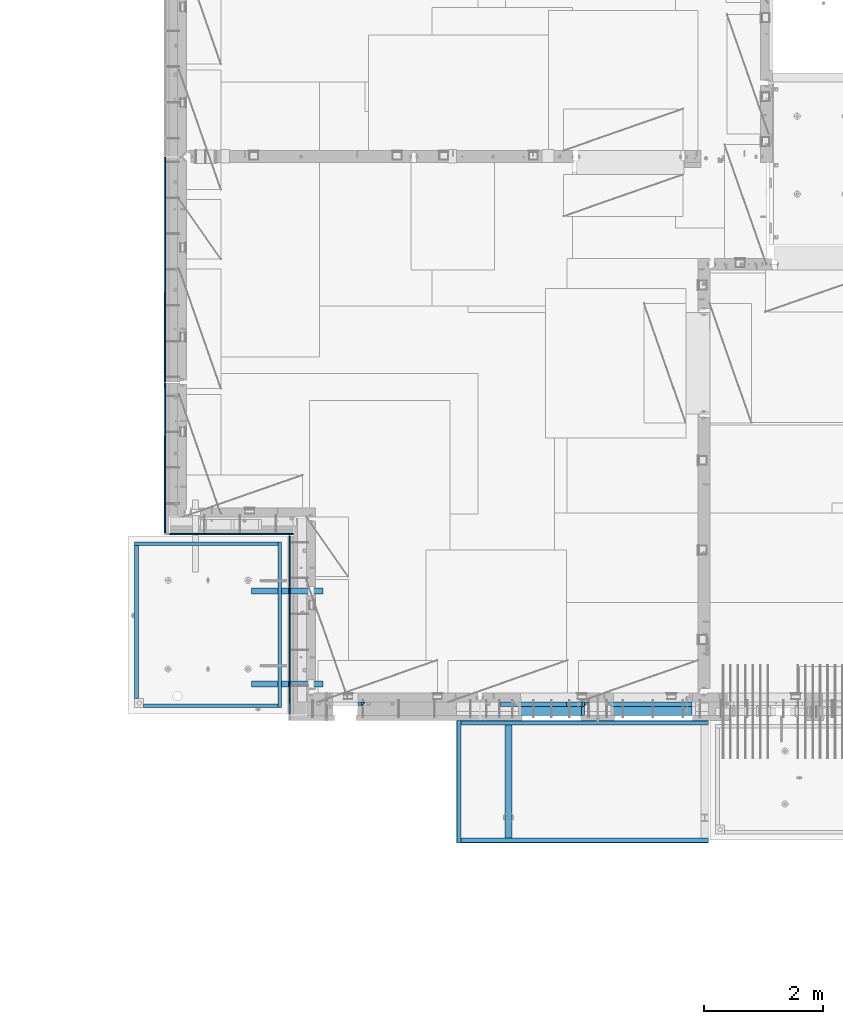
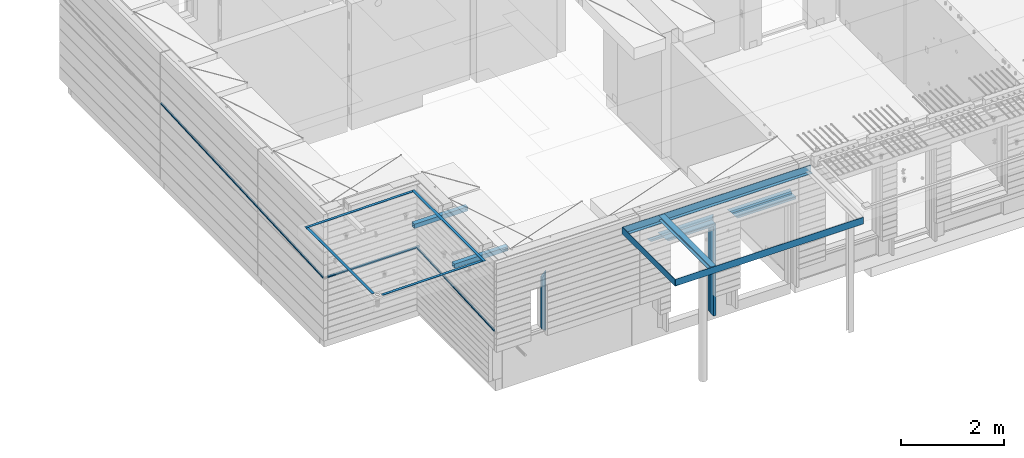
# One storey, part 85 of 325: 25 beams, 13 elements without a shape of their own.
"""IFC2X3 building model written with IfcOpenShell, lengths in millimetres."""

from ifc_helpers import new_model, si_unit, frame, origin_with_axes, place, context, subcontext, project, spatial, faceted_brep, material, type_object, element, aggregate, save


model = new_model("IFC2X3")

# Units and contexts
model_context = context("Model", 3, precision=1e-05, world=origin_with_axes())
body_context = subcontext(model_context, "Body", "Model", "MODEL_VIEW")
ifc_project = project(units=[si_unit("LENGTHUNIT", "METRE", prefix="MILLI"), si_unit("AREAUNIT", "SQUARE_METRE"), si_unit("VOLUMEUNIT", "CUBIC_METRE"), si_unit("MASSUNIT", "GRAM", prefix="KILO"), si_unit("TIMEUNIT", "SECOND"), si_unit("PLANEANGLEUNIT", "RADIAN"), si_unit("SOLIDANGLEUNIT", "STERADIAN"), si_unit("THERMODYNAMICTEMPERATUREUNIT", "DEGREE_CELSIUS"), si_unit("LUMINOUSINTENSITYUNIT", "LUMEN")], contexts=[model_context])

# Site, building, storey
site_placement = place(None, origin_with_axes())
site = spatial("IfcSite", under=ifc_project, at=site_placement, CompositionType="ELEMENT")
building_placement = place(site_placement, origin_with_axes())
building = spatial("IfcBuilding", under=site, at=building_placement, CompositionType="ELEMENT")
storey_placement = place(building_placement, origin_with_axes())
storey = spatial("IfcBuildingStorey", under=building, at=storey_placement, Name="1", CompositionType="ELEMENT", Elevation=0.0)

# Assembly, beams
assembly_1_placement = place(storey_placement, origin_with_axes())
assembly_1 = element("IfcElementAssembly", 1, at=assembly_1_placement, inside=storey, AssemblyPlace="NOTDEFINED", PredefinedType="REINFORCEMENT_UNIT")
ifc_material_1 = material(Name="CONCRETE/C25/30")
beam_type_1 = type_object("IfcBeamType", PredefinedType="NOTDEFINED")
beam_1_placement = place(assembly_1_placement, frame((15034.9997605339, 7815.0, 83940.0), z_axis=(0.0, 0.0, -1.0), x_axis=(1.0, 0.0, 0.0)))
beam_1 = element("IfcBeam", 2, at=beam_1_placement, type_object=beam_type_1, material=ifc_material_1, context=body_context, shape_type="Brep", body=[
    faceted_brep([(1425.00019073487, -35.0, 35.0), (1425.00019073487, -35.0, -35.0), (1425.00019073487, 35.0, 35.0), (70.0000000000164, -35.0, 35.0), (70.0000000000164, 35.0, 35.0), (0.0, -35.0, -35.0)], [[[0, 1, 2]], [[3, 0, 2, 4]], [[3, 4, 5]], [[0, 3, 5, 1]], [[4, 2, 1, 5]]]),
])
beam_2_placement = place(assembly_1_placement, frame((13485.0003327385, 7815.0, 83940.0), z_axis=(0.0, 0.0, -1.0), x_axis=(1.0, 0.0, 0.0)))
beam_2 = element("IfcBeam", 3, at=beam_2_placement, type_object=beam_type_1, material=ifc_material_1, context=body_context, shape_type="Brep", body=[
    faceted_brep([(70.0000000000164, -35.0, 35.0), (70.0000000000164, 35.0, 35.0), (0.0, -35.0, -35.0), (1249.99904632568, -35.0, -35.0), (1179.99904632569, -35.0, 35.0), (1179.99904632569, 35.0, 35.0)], [[[0, 1, 2]], [[0, 2, 3, 4]], [[1, 0, 4, 5]], [[2, 1, 5, 3]], [[4, 3, 5]]]),
])
beam_3_placement = place(assembly_1_placement, frame((14699.9993790642, 7815.0, 83975.0), z_axis=(-1.0, 3.00000001838171e-08, 0.0), x_axis=(0.0, 0.0, -1.0)))
beam_3 = element("IfcBeam", 4, at=beam_3_placement, type_object=beam_type_1, material=ifc_material_1, context=body_context, shape_type="Brep", body=[
    faceted_brep([(2245.0, -35.0, 35.0), (70.0000000000164, -35.0, 35.0), (0.0, -35.0, -35.0), (2245.0, -35.0, -35.0), (2245.0, 35.0, 35.0), (70.0000000000164, 35.0, 35.0)], [[[0, 1, 2, 3]], [[0, 3, 4]], [[1, 0, 4, 5]], [[1, 5, 2]], [[4, 3, 2, 5]]]),
])
beam_type_2 = type_object("IfcBeamType", PredefinedType="NOTDEFINED")
beam_4_placement = place(assembly_1_placement, frame((13255.0003327385, 7815.0, 83880.0), z_axis=(0.0, 0.0, -1.0), x_axis=(1.0, 0.0, 0.0)))
beam_4 = element("IfcBeam", 5, at=beam_4_placement, type_object=beam_type_2, material=ifc_material_1, context=body_context, shape_type="Brep", body=[
    faceted_brep([(345.640071966709, 35.0, 25.0), (343.845200171838, -35.0, 25.0), (343.845200171838, -35.0, 18.8461538461561), (345.640071966709, 35.0, 20.6410256410309), (50.0000000000036, 35.0, 25.0), (50.0000000000055, -35.0, 25.0), (0.0, 35.0, -25.0), (0.0, -35.0, -25.0), (1109.99904632568, -35.0, -25.0), (1066.15289247952, -35.0, 18.8461538461561), (1064.35802068466, 35.0, 20.6410256410309), (1109.99904632568, 35.0, -25.0)], [[[0, 1, 2, 3]], [[1, 0, 4, 5]], [[6, 7, 5, 4]], [[2, 1, 5, 7, 8, 9]], [[3, 2, 9, 10]], [[6, 4, 0, 3, 10, 11]], [[7, 6, 11, 8]], [[10, 9, 8, 11]]]),
])
beam_5_placement = place(assembly_1_placement, frame((15104.9997605339, 7815.0, 83880.0), z_axis=(0.0, 0.0, -1.0), x_axis=(1.0, 0.0, 0.0)))
beam_5 = element("IfcBeam", 6, at=beam_5_placement, type_object=beam_type_2, material=ifc_material_1, context=body_context, shape_type="Brep", body=[
    faceted_brep([(1355.00019073487, -35.0, -25.0), (1355.00019073487, 35.0, -25.0), (1355.00019073487, 35.0, 20.6410256410309), (1355.00019073487, -35.0, 18.8461538461561), (45.6412163758905, 35.0, 20.6410256410309), (43.8463445810194, -35.0, 18.8461538461561), (0.0, -35.0, -25.0), (0.0, 35.0, -25.0)], [[[0, 1, 2, 3]], [[3, 2, 4, 5]], [[0, 3, 5, 6]], [[1, 0, 6, 7]], [[2, 1, 7, 4]], [[6, 5, 4, 7]]]),
])
beam_6_placement = place(assembly_1_placement, frame((14639.9993790642, 7815.0, 83905.0), z_axis=(-1.0, 3.00000001838171e-08, 0.0), x_axis=(0.0, 0.0, -1.0)))
beam_6 = element("IfcBeam", 7, at=beam_6_placement, type_object=beam_type_2, material=ifc_material_1, context=body_context, shape_type="Brep", body=[
    faceted_brep([(2175.0, -35.0, -25.0), (2175.0, 35.0, -25.0), (2175.0, 35.0, 20.6410256410254), (2175.0, -35.0, 18.8461538461543), (63.8461538461561, -35.0, 18.8461538461543), (2155.0, -35.0, 18.8461538461543), (2155.0, 35.0, 20.6410256410254), (65.6410256410309, 35.0, 20.6410256410254), (45.6410256410309, 35.0, 20.6410256410254), (43.8461538461561, -35.0, 18.8461538461543), (0.0, 35.0, -25.0), (0.0, -35.0, -25.0)], [[[0, 1, 2, 3]], [[4, 5, 6, 7, 8, 9]], [[1, 10, 8, 7, 6, 2]], [[5, 3, 2, 6]], [[4, 9, 11, 0, 3, 5]], [[8, 10, 11, 9]], [[11, 10, 1, 0]]]),
])
ifc_material_2 = material(Name="TIMBER")
beam_type_3 = type_object("IfcBeamType", Name="50X150", PredefinedType="NOTDEFINED")
beam_7_placement = place(assembly_1_placement, frame((15104.9997605339, 7705.0, 83880.0), z_axis=(0.0, 0.0, -1.0), x_axis=(1.0, 0.0, 0.0)))
beam_7 = element("IfcBeam", 8, at=beam_7_placement, type_object=beam_type_3, material=ifc_material_2, ObjectType="50X150", context=body_context, shape_type="Brep", body=[
    faceted_brep([(1354.66019073487, -75.0, 25.0), (1354.66019073487, -75.0, -25.0), (1354.66019073487, 75.0, -25.0), (1354.66019073487, 75.0, 25.0), (50.0000000000036, -75.0, 25.0), (0.0, -75.0, -25.0), (0.0, 75.0, -25.0), (50.0000000000036, 75.0, 25.0)], [[[0, 1, 2, 3]], [[1, 0, 4, 5]], [[2, 1, 5, 6]], [[3, 2, 6, 7]], [[0, 3, 7, 4]], [[4, 7, 6, 5]]]),
])
beam_8_placement = place(assembly_1_placement, frame((13555.0003327385, 7705.0, 83880.0), z_axis=(0.0, 0.0, -1.0), x_axis=(1.0, 0.0, 0.0)))
beam_8 = element("IfcBeam", 9, at=beam_8_placement, type_object=beam_type_3, material=ifc_material_2, ObjectType="50X150", context=body_context, shape_type="Brep", body=[
    faceted_brep([(50.0000000000036, -75.0, 25.0), (50.0000000000036, 75.0, 25.0), (0.0, 75.0, -25.0), (0.0, -75.0, -25.0), (1109.99904632568, -75.0, -25.0), (1059.99904632568, -75.0, 25.0), (1059.99904632568, 75.0, 25.0), (1109.99904632568, 75.0, -25.0)], [[[0, 1, 2, 3]], [[0, 3, 4, 5]], [[1, 0, 5, 6]], [[2, 1, 6, 7]], [[3, 2, 7, 4]], [[6, 5, 4, 7]]]),
])
beam_9_placement = place(assembly_1_placement, frame((14639.9993790642, 7705.0, 83905.0), z_axis=(-1.0, 3.00000001838171e-08, 0.0), x_axis=(0.0, 0.0, -1.0)))
beam_9 = element("IfcBeam", 10, at=beam_9_placement, type_object=beam_type_3, material=ifc_material_2, ObjectType="50X150", context=body_context, shape_type="Brep", body=[
    faceted_brep([(2175.0, -75.0, 25.0), (2175.0, -75.0, -25.0), (2175.0, 75.0, -25.0), (2175.0, 75.0, 25.0), (0.0, -75.0, -25.0), (0.0, 75.0, -25.0), (50.0000000000036, 75.0, 25.0), (50.0000000000036, -75.0, 25.0)], [[[0, 1, 2, 3]], [[4, 5, 2, 1]], [[3, 2, 5, 6]], [[0, 3, 6, 7]], [[1, 0, 7, 4]], [[7, 6, 5, 4]]]),
])
aggregate(assembly_1, [beam_1, beam_4, beam_5, beam_2, beam_7, beam_6, beam_3, beam_8, beam_9])

# Assembly, beam
assembly_2_placement = place(storey_placement, origin_with_axes())
assembly_2 = element("IfcElementAssembly", 11, at=assembly_2_placement, inside=storey, AssemblyPlace="NOTDEFINED", PredefinedType="REINFORCEMENT_UNIT")
ifc_material_3 = material(Name="TIMBER/T24")
beam_type_4 = type_object("IfcBeamType", PredefinedType="NOTDEFINED")
beam_10_placement = place(assembly_2_placement, frame((9722.5, 10631.2198813113, 83239.1084473989), z_axis=(1.0, 0.0, 0.0), x_axis=(0.0, -0.998808802312005, -0.0487952500153176)))
beam_10 = element("IfcBeam", 12, at=beam_10_placement, type_object=beam_type_4, material=ifc_material_3, context=body_context, shape_type="Brep", body=[
    faceted_brep([(9.72067937254906e-09, -25.0049072368565, -2.50000010478834), (-1.81898940354586e-12, -0.00592035360750742, -12.5), (2988.55996575396, -1.2821692507714e-07, -12.5), (2988.55996575396, -25.0, -2.49999958879198), (0.0, 25.0, -12.5), (0.0, 25.0, 12.5), (2988.55996575396, 25.0, 12.5), (2988.55996575396, 25.0, -12.5), (0.0, -25.0, 12.5), (2988.55996575396, -25.0, 12.5)], [[[0, 1, 2, 3]], [[4, 5, 6, 7]], [[5, 8, 9, 6]], [[9, 8, 0, 3]], [[7, 6, 9, 3, 2]], [[4, 7, 2, 1]], [[8, 5, 4, 1, 0]]]),
])
aggregate(assembly_2, [beam_10])

assembly_3_placement = place(storey_placement, origin_with_axes())
assembly_3 = element("IfcElementAssembly", 13, at=assembly_3_placement, inside=storey, AssemblyPlace="NOTDEFINED", PredefinedType="REINFORCEMENT_UNIT")
beam_11_placement = place(assembly_3_placement, frame((7725.00005960496, 10662.5, 83239.8157983143), z_axis=(0.0, 1.0, 0.0), x_axis=(1.0, 0.0, 0.0)))
beam_11 = element("IfcBeam", 14, at=beam_11_placement, type_object=beam_type_4, material=ifc_material_3, context=body_context, shape_type="Brep", body=[
    faceted_brep([(2060.00479019237, -24.9999999999854, 0.0), (0.0, -25.0, 0.0), (-1.45519152283669e-11, -3.63797880709171e-12, -12.5), (2060.00479019237, 1.45519152283669e-11, -12.5), (0.0, 25.0, -12.5), (0.0, 25.0, 12.5), (2060.00479019237, 25.0, 12.5), (2060.00479019237, 25.0, -12.5), (0.0, -25.0, 12.5), (2060.00479019237, -25.0, 12.5)], [[[0, 1, 2, 3]], [[4, 5, 6, 7]], [[5, 8, 9, 6]], [[7, 6, 9, 0, 3]], [[4, 7, 3, 2]], [[8, 5, 4, 2, 1]], [[9, 8, 1, 0]]]),
])
aggregate(assembly_3, [beam_11])

assembly_4_placement = place(storey_placement, origin_with_axes())
assembly_4 = element("IfcElementAssembly", 15, at=assembly_4_placement, inside=storey, AssemblyPlace="NOTDEFINED", PredefinedType="REINFORCEMENT_UNIT")
beam_12_placement = place(assembly_4_placement, frame((7642.5, 13196.2344335996, 83364.4291608322), z_axis=(1.0, 0.0, 0.0), x_axis=(0.0, -0.998780195036966, -0.0493773430018267)))
beam_12 = element("IfcBeam", 16, at=beam_12_placement, type_object=beam_type_4, material=ifc_material_3, context=body_context, shape_type="Brep", body=[
    faceted_brep([(-0.000167481186508667, -25.1808586047118, -0.208622932433173), (-3.63797880709171e-12, -0.00150569378456566, -12.5), (2523.07761831955, -2.33796088455711, -12.5), (2523.07761831955, -25.0000000000146, -1.43745732237585), (0.0, 25.0, -12.5), (0.0, 25.0, 12.5), (2523.07761831955, 25.0, 12.5), (2523.07761831955, 25.0, -12.5), (0.0, -25.0, 12.5), (2523.07761831955, -25.0000000000146, 12.5)], [[[0, 1, 2, 3]], [[4, 5, 6, 7]], [[5, 8, 9, 6]], [[9, 8, 0, 3]], [[7, 6, 9, 3, 2]], [[4, 7, 2, 1]], [[8, 5, 4, 1, 0]]]),
])
aggregate(assembly_4, [beam_12])

assembly_5_placement = place(storey_placement, origin_with_axes())
assembly_5 = element("IfcElementAssembly", 17, at=assembly_5_placement, inside=storey, AssemblyPlace="NOTDEFINED", PredefinedType="REINFORCEMENT_UNIT")
beam_13_placement = place(assembly_5_placement, frame((7642.5, 16971.1699461518, 83548.8576061738), z_axis=(1.0, 0.0, 0.0), x_axis=(0.0, -0.998808676266891, -0.0487978300130376)))
beam_13 = element("IfcBeam", 18, at=beam_13_placement, type_object=beam_type_4, material=ifc_material_3, context=body_context, shape_type="Brep", body=[
    faceted_brep([(-6.3338487962028e-05, -25.1831539043487, -0.208622932433173), (-3.63797880709171e-12, -0.00381015073799063, -12.5), (3764.43457031995, -1.3056310826214, -12.5), (3764.43457031995, -25.0, -0.933518151315184), (0.0, 25.0, -12.5), (0.0, 25.0, 12.5), (3764.43457031994, 25.0, 12.5), (3764.43457031994, 25.0, -12.5), (0.0, -25.0, 12.5), (3764.43457031995, -25.0, 12.5)], [[[0, 1, 2, 3]], [[4, 5, 6, 7]], [[5, 8, 9, 6]], [[9, 8, 0, 3]], [[7, 6, 9, 3, 2]], [[4, 7, 2, 1]], [[8, 5, 4, 1, 0]]]),
])
aggregate(assembly_5, [beam_13])

# Assemblies, beams
assembly_6_placement = place(storey_placement, origin_with_axes())
assembly_6 = element("IfcElementAssembly", 19, at=assembly_6_placement, inside=storey, AssemblyPlace="NOTDEFINED", PredefinedType="REINFORCEMENT_UNIT")
assembly_7_placement = place(assembly_6_placement, origin_with_axes())
assembly_7 = element("IfcElementAssembly", 20, at=assembly_7_placement, AssemblyPlace="NOTDEFINED", PredefinedType="NOTDEFINED")
ifc_material_4 = material(Name="Undefined/350")
beam_type_5 = type_object("IfcBeamType", Name="100X100X5", PredefinedType="NOTDEFINED")
beam_14_placement = place(assembly_7_placement, frame((9089.99655739692, 9710.00014320107, 84555.0), z_axis=(0.0, 0.0, 1.0), x_axis=(0.999999999752625, -2.22429999942101e-05, 0.0)))
beam_14 = element("IfcBeam", 21, at=beam_14_placement, type_object=beam_type_5, material=ifc_material_4, ObjectType="100X100X5", context=body_context, shape_type="Brep", body=[
    faceted_brep([(1156.2510802317, 44.9999999999982, 10.8253175473074), (1156.25107855315, 50.0256005946221, 10.8253175473074), (1160.82639610046, 50.0256021227788, 6.25), (1160.82639777901, 44.9999999999982, 6.25), (1150.00108023171, 44.9999999999982, 12.5), (1150.00107855316, 50.0255985071226, 12.5), (1143.75108023171, 44.9999999999982, 10.8253175473074), (1143.75107855316, 50.0255964196231, 10.8253175473074), (1139.1757626844, 44.9999999999982, 6.25), (1139.17576100585, 50.0255948914664, 6.25), (1137.5010802317, 44.9999999999982, 0.0), (1137.50107855316, 50.0255943321226, 0.0), (1139.1757626844, 44.9999999999982, -6.25), (1139.17576100585, 50.0255948914664, -6.25), (1143.75108023171, 44.9999999999982, -10.8253175473074), (1143.75107855316, 50.0255964196231, -10.8253175473074), (1150.00108023171, 44.9999999999982, -12.5), (1150.00107855316, 50.0255985071226, -12.5), (1156.2510802317, 44.9999999999982, -10.8253175473074), (1156.25107855315, 50.0256005946221, -10.8253175473074), (1160.82639777901, 44.9999999999982, -6.25), (1160.82639610046, 50.0256021227788, -6.25), (1162.50108023171, 44.9999999999982, 0.0), (1162.50107855316, 50.0256026821226, 0.0), (1156.25111195316, -49.9743994042774, 10.8253175473074), (1156.25111029171, -44.9999999999991, 10.8253175473074), (1160.82642783901, -44.9999999999991, 6.25), (1160.82642950046, -49.9743978761207, 6.25), (1150.00111195316, -49.9744014917787, 12.5), (1150.00111029171, -44.9999999999991, 12.5), (1143.75111195316, -49.9744035792783, 10.8253175473074), (1143.75111029171, -44.9999999999991, 10.8253175473074), (1139.17579440585, -49.9744051074349, 6.25), (1139.1757927444, -44.9999999999991, 6.25), (1137.50111195316, -49.9744056667778, 0.0), (1137.50111029171, -44.9999999999991, 0.0), (1139.17579440585, -49.9744051074349, -6.25), (1139.1757927444, -44.9999999999991, -6.25), (1143.75111195316, -49.9744035792783, -10.8253175473074), (1143.75111029171, -44.9999999999991, -10.8253175473074), (1150.00111195316, -49.9744014917787, -12.5), (1150.00111029171, -44.9999999999991, -12.5), (1156.25111195316, -49.9743994042774, -10.8253175473074), (1156.25111029171, -44.9999999999991, -10.8253175473074), (1160.82642950046, -49.9743978761207, -6.25), (1160.82642783901, -44.9999999999991, -6.25), (1162.50111195316, -49.9743973167779, 0.0), (1162.50111029171, -44.9999999999991, 0.0), (1.81898940354586e-12, -50.0000000000009, -50.0), (1.81898940354586e-12, 49.9999999999991, -50.0), (1200.00449189278, 49.9999999999982, -50.0), (1200.00449189278, -50.0000000000009, -50.0), (1.81898940354586e-12, 49.9999999999991, 50.0), (1.81898940354586e-12, -50.0000000000009, 50.0), (1200.00449189278, -50.0000000000009, 50.0), (1200.00449189278, 49.9999999999982, 50.0), (0.0, 44.9999999999991, 45.0), (1.81898940354586e-12, -45.0000000000009, 45.0), (1.81898940354586e-12, -45.0000000000009, -45.0), (0.0, 44.9999999999991, -45.0), (1200.00449189278, 44.9999999999982, -45.0), (1200.00449189278, 44.9999999999982, 45.0), (1200.00449189278, -45.0000000000009, 45.0), (1200.00449189278, -45.0000000000009, -45.0)], [[[0, 1, 2, 3]], [[4, 5, 1, 0]], [[6, 7, 5, 4]], [[8, 9, 7, 6]], [[10, 11, 9, 8]], [[12, 13, 11, 10]], [[14, 15, 13, 12]], [[16, 17, 15, 14]], [[18, 19, 17, 16]], [[20, 21, 19, 18]], [[22, 23, 21, 20]], [[3, 2, 23, 22]], [[24, 25, 26, 27]], [[28, 29, 25, 24]], [[30, 31, 29, 28]], [[32, 33, 31, 30]], [[34, 35, 33, 32]], [[36, 37, 35, 34]], [[38, 39, 37, 36]], [[40, 41, 39, 38]], [[42, 43, 41, 40]], [[44, 45, 43, 42]], [[46, 47, 45, 44]], [[27, 26, 47, 46]], [[48, 49, 50, 51]], [[52, 53, 54, 55]], [[49, 52, 55, 50], [1, 5, 7, 9, 11, 13, 15, 17, 19, 21, 23, 2]], [[48, 53, 52, 49], [56, 57, 58, 59]], [[56, 59, 60, 61], [18, 16, 14, 12, 10, 8, 6, 4, 0, 3, 22, 20]], [[57, 56, 61, 62]], [[58, 57, 62, 63], [25, 29, 31, 33, 35, 37, 39, 41, 43, 45, 47, 26]], [[59, 58, 63, 60]], [[54, 51, 50, 55], [62, 61, 60, 63]], [[53, 48, 51, 54], [42, 40, 38, 36, 34, 32, 30, 28, 24, 27, 46, 44]]]),
])
aggregate(assembly_7, [beam_14])
assembly_8_placement = place(assembly_6_placement, origin_with_axes())
assembly_8 = element("IfcElementAssembly", 22, at=assembly_8_placement, AssemblyPlace="NOTDEFINED", PredefinedType="NOTDEFINED")
beam_15_placement = place(assembly_8_placement, frame((9089.99655739692, 8155.00014320107, 84555.0), z_axis=(0.0, 0.0, 1.0), x_axis=(0.999999999752625, -2.22429999942101e-05, 0.0)))
beam_15 = element("IfcBeam", 23, at=beam_15_placement, type_object=beam_type_5, material=ifc_material_4, ObjectType="100X100X5", context=body_context, shape_type="Brep", body=[
    faceted_brep([(1156.2510802317, 44.9999999999982, 10.8253175473074), (1156.25107855315, 50.0256005946221, 10.8253175473074), (1160.82639610046, 50.0256021227788, 6.25), (1160.82639777901, 44.9999999999982, 6.25), (1150.00108023171, 44.9999999999982, 12.5), (1150.00107855316, 50.0255985071226, 12.5), (1143.75108023171, 44.9999999999982, 10.8253175473074), (1143.75107855316, 50.0255964196231, 10.8253175473074), (1139.1757626844, 44.9999999999982, 6.25), (1139.17576100585, 50.0255948914664, 6.25), (1137.5010802317, 44.9999999999982, 0.0), (1137.50107855316, 50.0255943321226, 0.0), (1139.1757626844, 44.9999999999982, -6.25), (1139.17576100585, 50.0255948914664, -6.25), (1143.75108023171, 44.9999999999982, -10.8253175473074), (1143.75107855316, 50.0255964196231, -10.8253175473074), (1150.00108023171, 44.9999999999982, -12.5), (1150.00107855316, 50.0255985071226, -12.5), (1156.2510802317, 44.9999999999982, -10.8253175473074), (1156.25107855315, 50.0256005946221, -10.8253175473074), (1160.82639777901, 44.9999999999982, -6.25), (1160.82639610046, 50.0256021227788, -6.25), (1162.50108023171, 44.9999999999982, 0.0), (1162.50107855316, 50.0256026821226, 0.0), (1156.25111195316, -49.9743994042774, 10.8253175473074), (1156.25111029171, -44.9999999999991, 10.8253175473074), (1160.82642783901, -44.9999999999991, 6.25), (1160.82642950046, -49.9743978761207, 6.25), (1150.00111195316, -49.9744014917787, 12.5), (1150.00111029171, -44.9999999999991, 12.5), (1143.75111195316, -49.9744035792783, 10.8253175473074), (1143.75111029171, -44.9999999999991, 10.8253175473074), (1139.17579440585, -49.9744051074349, 6.25), (1139.1757927444, -44.9999999999991, 6.25), (1137.50111195316, -49.9744056667778, 0.0), (1137.50111029171, -44.9999999999991, 0.0), (1139.17579440585, -49.9744051074349, -6.25), (1139.1757927444, -44.9999999999991, -6.25), (1143.75111195316, -49.9744035792783, -10.8253175473074), (1143.75111029171, -44.9999999999991, -10.8253175473074), (1150.00111195316, -49.9744014917787, -12.5), (1150.00111029171, -44.9999999999991, -12.5), (1156.25111195316, -49.9743994042774, -10.8253175473074), (1156.25111029171, -44.9999999999991, -10.8253175473074), (1160.82642950046, -49.9743978761207, -6.25), (1160.82642783901, -44.9999999999991, -6.25), (1162.50111195316, -49.9743973167779, 0.0), (1162.50111029171, -44.9999999999991, 0.0), (1.81898940354586e-12, -50.0000000000009, -50.0), (1.81898940354586e-12, 49.9999999999991, -50.0), (1200.00449189278, 49.9999999999982, -50.0), (1200.00449189278, -50.0000000000009, -50.0), (1.81898940354586e-12, 49.9999999999991, 50.0), (1.81898940354586e-12, -50.0000000000009, 50.0), (1200.00449189278, -50.0000000000009, 50.0), (1200.00449189278, 49.9999999999982, 50.0), (0.0, 44.9999999999991, 45.0), (1.81898940354586e-12, -45.0000000000009, 45.0), (1.81898940354586e-12, -45.0000000000009, -45.0), (0.0, 44.9999999999991, -45.0), (1200.00449189278, 44.9999999999982, -45.0), (1200.00449189278, 44.9999999999982, 45.0), (1200.00449189278, -45.0000000000009, 45.0), (1200.00449189278, -45.0000000000009, -45.0)], [[[0, 1, 2, 3]], [[4, 5, 1, 0]], [[6, 7, 5, 4]], [[8, 9, 7, 6]], [[10, 11, 9, 8]], [[12, 13, 11, 10]], [[14, 15, 13, 12]], [[16, 17, 15, 14]], [[18, 19, 17, 16]], [[20, 21, 19, 18]], [[22, 23, 21, 20]], [[3, 2, 23, 22]], [[24, 25, 26, 27]], [[28, 29, 25, 24]], [[30, 31, 29, 28]], [[32, 33, 31, 30]], [[34, 35, 33, 32]], [[36, 37, 35, 34]], [[38, 39, 37, 36]], [[40, 41, 39, 38]], [[42, 43, 41, 40]], [[44, 45, 43, 42]], [[46, 47, 45, 44]], [[27, 26, 47, 46]], [[48, 49, 50, 51]], [[52, 53, 54, 55]], [[49, 52, 55, 50], [1, 5, 7, 9, 11, 13, 15, 17, 19, 21, 23, 2]], [[48, 53, 52, 49], [56, 57, 58, 59]], [[56, 59, 60, 61], [18, 16, 14, 12, 10, 8, 6, 4, 0, 3, 22, 20]], [[57, 56, 61, 62]], [[58, 57, 62, 63], [25, 29, 31, 33, 35, 37, 39, 41, 43, 45, 47, 26]], [[59, 58, 63, 60]], [[54, 51, 50, 55], [62, 61, 60, 63]], [[53, 48, 51, 54], [42, 40, 38, 36, 34, 32, 30, 28, 24, 27, 46, 44]]]),
])
aggregate(assembly_8, [beam_15])
ifc_material_5 = material(Name="CONCRETE/Concrete_Undefined")
beam_type_6 = type_object("IfcBeamType", PredefinedType="NOTDEFINED")
beam_16_placement = place(assembly_6_placement, frame((9529.73225763201, 10500.0586098955, 84724.6636624749), z_axis=(-0.00918619300035676, -2.22000000585005e-07, 0.99995780603889), x_axis=(-0.999957805748064, -2.41189999941813e-05, -0.00918619299768504)))
beam_16 = element("IfcBeam", 24, at=beam_16_placement, type_object=beam_type_6, material=ifc_material_5, context=body_context, shape_type="Brep", body=[
    faceted_brep([(2.5465851649642e-11, 29.9999999999982, -4.99999999998545), (-2.91038304567337e-11, 29.9999999999982, 5.0), (2394.89682739776, 29.9999999999964, 5.0), (2394.89682739781, 30.0, -4.99999999998545), (-2.5465851649642e-11, -30.0000000000018, 5.0), (2394.89682739776, -30.0000000000036, 5.0), (2.72848410531878e-11, -30.0000000000018, -4.99999999998545), (2394.89682739781, -30.0, -4.99999999998545)], [[[0, 1, 2, 3]], [[1, 4, 5, 2]], [[4, 6, 7, 5]], [[6, 0, 3, 7]], [[5, 7, 3, 2]], [[6, 4, 1, 0]]]),
])
beam_17_placement = place(assembly_6_placement, frame((7164.89422591706, 10470.0076633258, 84701.6030105556), z_axis=(0.0, -1.17599999975856e-06, 0.999999999999309), x_axis=(4.13430000058061e-05, -0.999999999144687, -1.176000002514e-06)))
beam_17 = element("IfcBeam", 25, at=beam_17_placement, type_object=beam_type_6, material=ifc_material_5, context=body_context, shape_type="Brep", body=[
    faceted_brep([(2.5465851649642e-11, 29.9999999999982, -4.99999999998545), (-2.91038304567337e-11, 29.9999999999982, 5.0), (2560.00574992944, 30.0000000000009, 5.00000000001455), (2560.00574992944, 30.0, -5.0), (-2.5465851649642e-11, -30.0000000000018, 5.0), (2560.00574992944, -29.9999999999991, 5.00000000001455), (2.72848410531878e-11, -30.0000000000018, -4.99999999998545), (2560.00574992944, -30.0, -5.0)], [[[0, 1, 2, 3]], [[1, 4, 5, 2]], [[4, 6, 7, 5]], [[6, 0, 3, 7]], [[5, 7, 3, 2]], [[6, 4, 1, 0]]]),
])
beam_18_placement = place(assembly_6_placement, frame((9559.6242765169, 7760.00786459139, 84724.2917943147), z_axis=(-2.9999991954625e-09, -0.000129499999950134, 0.999999991614875), x_axis=(2.43220000075427e-05, 0.999999991319095, 0.000129500000041638)))
beam_18 = element("IfcBeam", 26, at=beam_18_placement, type_object=beam_type_6, material=ifc_material_5, context=body_context, shape_type="Brep", body=[
    faceted_brep([(2.5465851649642e-11, 29.9999999999982, -4.99999999998545), (-2.91038304567337e-11, 29.9999999999982, 5.0), (2770.00002322912, 29.9999999999982, 5.00000000001455), (2770.00002322912, 29.9999999999982, -4.9999999999709), (-2.5465851649642e-11, -30.0000000000018, 5.0), (2770.00002322912, -30.0000000000018, 5.0), (2.72848410531878e-11, -30.0000000000018, -4.99999999998545), (2770.00002322912, -30.0000000000018, -4.99999999998545)], [[[0, 1, 2, 3]], [[1, 4, 5, 2]], [[4, 6, 7, 5]], [[6, 0, 3, 7]], [[5, 7, 3, 2]], [[6, 4, 1, 0]]]),
])
beam_19_placement = place(assembly_6_placement, frame((9529.67128970205, 7789.99860988154, 84725.2790473986), z_axis=(-0.00918361699724776, 4.9999998721906e-09, 0.999957829700257), x_axis=(-0.999957829700102, 5.55999999934641e-07, -0.00918361699724765)))
beam_19 = element("IfcBeam", 27, at=beam_19_placement, type_object=beam_type_6, material=ifc_material_5, context=body_context, shape_type="Brep", body=[
    faceted_brep([(2.5465851649642e-11, 29.9999999999982, -4.99999999998545), (-2.91038304567337e-11, 29.9999999999982, 5.0), (2244.79868782777, 30.0, 5.00000000001455), (2244.79868782778, 30.0, -4.99999999995634), (-2.5465851649642e-11, -30.0000000000018, 5.0), (2244.79868782778, -30.0000000000009, 5.00000000001455), (2.72848410531878e-11, -30.0000000000018, -4.99999999998545), (2244.79868782778, -30.0, -4.9999999999709)], [[[0, 1, 2, 3]], [[1, 4, 5, 2]], [[4, 6, 7, 5]], [[6, 0, 3, 7]], [[5, 7, 3, 2]], [[6, 4, 1, 0]]]),
])
aggregate(assembly_6, [beam_16, assembly_7, assembly_8, beam_17, beam_18, beam_19])

# Assembly, beams
assembly_9_placement = place(storey_placement, origin_with_axes())
assembly_9 = element("IfcElementAssembly", 28, at=assembly_9_placement, inside=storey, AssemblyPlace="NOTDEFINED", PredefinedType="REINFORCEMENT_UNIT")
beam_type_7 = type_object("IfcBeamType", PredefinedType="NOTDEFINED")
beam_20_placement = place(assembly_9_placement, frame((10965.0005234733, 7820.0, 83975.0), z_axis=(-1.0, 3.00000001838171e-08, 0.0), x_axis=(0.0, 0.0, -1.0)))
beam_20 = element("IfcBeam", 29, at=beam_20_placement, type_object=beam_type_7, material=ifc_material_1, context=body_context, shape_type="Brep", body=[
    faceted_brep([(1455.0, -30.0, -30.0), (1395.00000000001, -30.0, 30.0), (60.0000000000073, -30.0, 30.0), (0.0, -30.0, -30.0), (1395.00000000001, 30.0, 30.0), (60.0000000000073, 30.0, 30.0)], [[[0, 1, 2, 3]], [[1, 0, 4]], [[1, 4, 5, 2]], [[5, 3, 2]], [[4, 0, 3, 5]]]),
])
beam_type_8 = type_object("IfcBeamType", PredefinedType="NOTDEFINED")
beam_21_placement = place(assembly_9_placement, frame((10900.0005234733, 7820.0, 83915.0), z_axis=(-1.0, 3.00000001838171e-08, 0.0), x_axis=(0.0, 0.0, -1.0)))
beam_21 = element("IfcBeam", 30, at=beam_21_placement, type_object=beam_type_8, material=ifc_material_1, context=body_context, shape_type="Brep", body=[
    faceted_brep([(0.0, -30.0, -35.0), (54.9034748914273, -30.0, 29.0540540540533), (56.2934362811066, 30.0, 30.6756756756768), (0.0, 30.0, -35.0), (1335.0, -30.0, -35.0), (1280.09652510857, -30.0, 29.0540540540533), (1278.70656371891, 30.0, 30.6756756756749), (1335.0, 30.0, -35.0)], [[[0, 1, 2, 3]], [[1, 0, 4, 5]], [[2, 1, 5, 6]], [[3, 2, 6, 7]], [[7, 4, 0, 3]], [[6, 5, 4, 7]]]),
])
aggregate(assembly_9, [beam_21, beam_20])

# Assembly, beam
assembly_10_placement = place(storey_placement, origin_with_axes())
assembly_10 = element("IfcElementAssembly", 31, at=assembly_10_placement, inside=storey, Name="Steel Assembly", AssemblyPlace="NOTDEFINED", PredefinedType="RIGID_FRAME")
ifc_material_6 = material(Name="STEEL/S355J2")
beam_type_9 = type_object("IfcBeamType", PredefinedType="NOTDEFINED")
beam_22_placement = place(assembly_10_placement, frame((12559.5300452044, 5495.0012862332, 84544.0), z_axis=(0.0, 0.0, 1.0), x_axis=(0.0, 1.0, 0.0)))
beam_22 = element("IfcBeam", 32, at=beam_22_placement, type_object=beam_type_9, material=ifc_material_6, context=body_context, shape_type="Brep", body=[
    faceted_brep([(0.0, 40.0, -80.0), (0.0, 40.0, 80.0), (2049.9987137668, 40.0, 80.0), (2049.9987137668, 40.0, -80.0), (0.0, 30.0, 80.0), (2049.9987137668, 30.0, 80.0), (0.0, 30.0, -70.0), (2049.9987137668, 30.0, -70.0), (0.0, -40.0, -70.0), (2049.9987137668, -40.0, -70.0), (0.0, -40.0, -80.0), (2049.9987137668, -40.0, -80.0)], [[[0, 1, 2, 3]], [[1, 4, 5, 2]], [[4, 6, 7, 5]], [[6, 8, 9, 7]], [[8, 10, 11, 9]], [[10, 0, 3, 11]], [[5, 7, 9, 11, 3, 2]], [[10, 8, 6, 4, 1, 0]]]),
])
aggregate(assembly_10, [beam_22])

assembly_11_placement = place(storey_placement, origin_with_axes())
assembly_11 = element("IfcElementAssembly", 33, at=assembly_11_placement, inside=storey, Name="Steel Assembly", AssemblyPlace="NOTDEFINED", PredefinedType="RIGID_FRAME")
beam_23_placement = place(assembly_11_placement, frame((16734.9994055559, 5535.0012862332, 84544.0), z_axis=(0.0, 0.0, 1.0), x_axis=(-1.0, 3.00000001838171e-08, 0.0)))
beam_23 = element("IfcBeam", 34, at=beam_23_placement, type_object=beam_type_9, material=ifc_material_6, context=body_context, shape_type="Brep", body=[
    faceted_brep([(0.0, 40.0, -80.0), (0.0, 40.0, 80.0), (4215.46936035156, 40.0, 80.0), (4215.46936035156, 40.0, -80.0), (0.0, 30.0, 80.0), (4215.46936035156, 30.0, 80.0), (0.0, 30.0, -70.0), (4215.46936035156, 30.0, -70.0), (0.0, -40.0, -70.0), (4215.46936035156, -40.0, -70.0), (0.0, -40.0, -80.0), (4215.46936035156, -40.0, -80.0)], [[[0, 1, 2, 3]], [[1, 4, 5, 2]], [[4, 6, 7, 5]], [[6, 8, 9, 7]], [[8, 10, 11, 9]], [[10, 0, 3, 11]], [[5, 7, 9, 11, 3, 2]], [[10, 8, 6, 4, 1, 0]]]),
])
aggregate(assembly_11, [beam_23])

assembly_12_placement = place(storey_placement, origin_with_axes())
assembly_12 = element("IfcElementAssembly", 35, at=assembly_12_placement, inside=storey, Name="Steel Assembly", AssemblyPlace="NOTDEFINED", PredefinedType="RIGID_FRAME")
beam_24_placement = place(assembly_12_placement, frame((12519.5300452044, 7504.99670859649, 84544.0), z_axis=(0.0, 0.0, 1.0), x_axis=(1.0, 0.0, 0.0)))
beam_24 = element("IfcBeam", 36, at=beam_24_placement, type_object=beam_type_9, material=ifc_material_6, context=body_context, shape_type="Brep", body=[
    faceted_brep([(0.0, 40.0, -80.0), (0.0, 40.0, 80.0), (4215.46936035156, 40.0, 80.0), (4215.46936035156, 40.0, -80.0), (0.0, 30.0, 80.0), (4215.46936035156, 30.0, 80.0), (0.0, 30.0, -70.0), (4215.46936035156, 30.0, -70.0), (0.0, -40.0, -70.0), (4215.46936035156, -40.0, -70.0), (0.0, -40.0, -80.0), (4215.46936035156, -40.0, -80.0)], [[[0, 1, 2, 3]], [[1, 4, 5, 2]], [[4, 6, 7, 5]], [[6, 8, 9, 7]], [[8, 10, 11, 9]], [[10, 0, 3, 11]], [[5, 7, 9, 11, 3, 2]], [[10, 8, 6, 4, 1, 0]]]),
])
aggregate(assembly_12, [beam_24])

assembly_13_placement = place(storey_placement, origin_with_axes())
assembly_13 = element("IfcElementAssembly", 37, at=assembly_13_placement, inside=storey, Name="Steel Assembly", AssemblyPlace="NOTDEFINED", PredefinedType="RIGID_FRAME")
beam_type_10 = type_object("IfcBeamType", Name="HEA120", PredefinedType="NOTDEFINED")
beam_25_placement = place(assembly_13_placement, frame((13389.9900452044, 5509.99723105742, 84567.0), z_axis=(0.0, 0.0, 1.0), x_axis=(0.0, 1.0, 0.0)))
beam_25 = element("IfcBeam", 38, at=beam_25_placement, type_object=beam_type_10, material=ifc_material_6, ObjectType="HEA120", context=body_context, shape_type="Brep", body=[
    faceted_brep([(0.0, 60.0, -57.0), (0.0, 60.0, -49.0), (2014.99947753906, 60.0, -49.0), (2014.99947753906, 60.0, -57.0), (0.0, 2.5, -49.0), (2014.99947753906, 2.5, -49.0), (0.0, 2.5, 49.0), (2014.99947753906, 2.5, 49.0), (0.0, 60.0, 49.0), (2014.99947753906, 60.0, 49.0), (0.0, 60.0, 57.0), (2014.99947753906, 60.0, 57.0), (0.0, -60.0, 57.0), (2014.99947753906, -60.0, 57.0), (0.0, -60.0, 49.0), (2014.99947753906, -60.0, 49.0), (0.0, -2.5, 49.0), (2014.99947753906, -2.5, 49.0), (0.0, -2.5, -49.0), (2014.99947753906, -2.5, -49.0), (0.0, -60.0, -49.0), (2014.99947753906, -60.0, -49.0), (0.0, -60.0, -57.0), (2014.99947753906, -60.0, -57.0)], [[[0, 1, 2, 3]], [[1, 4, 5, 2]], [[4, 6, 7, 5]], [[6, 8, 9, 7]], [[8, 10, 11, 9]], [[10, 12, 13, 11]], [[12, 14, 15, 13]], [[14, 16, 17, 15]], [[16, 18, 19, 17]], [[18, 20, 21, 19]], [[20, 22, 23, 21]], [[22, 0, 3, 23]], [[5, 7, 9, 11, 13, 15, 17, 19, 21, 23, 3, 2]], [[22, 20, 18, 16, 14, 12, 10, 8, 6, 4, 1, 0]]]),
])
aggregate(assembly_13, [beam_25])

save(model, "model.ifc")
